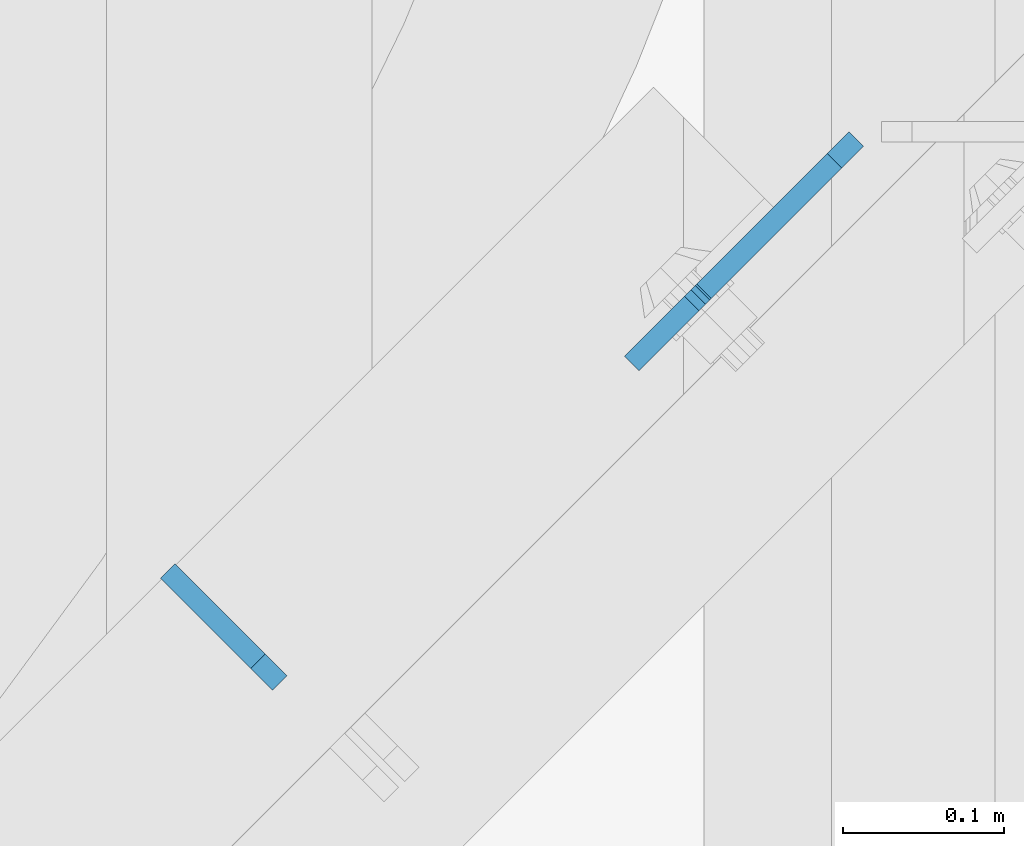
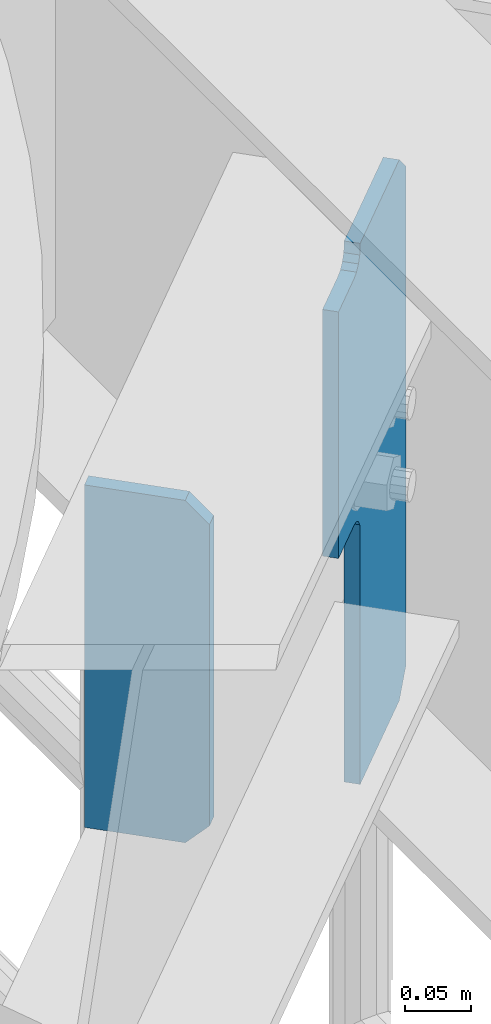
# One storey, part 1513 of 1876: 2 plates, 2 elements without a shape of their own.
"""IFC2X3 building model written with IfcOpenShell, lengths in millimetres."""

import ifcopenshell
import ifcopenshell.guid

model = None  # the IFC model being written
_history = None  # IfcOwnerHistory: only IFC2X3 demands one
_inside = {}  # id of a spatial element -> (the spatial element, [elements in it])
_under = {}  # id of a project, library or spatial element -> (it, [spatial elements below it])
_declared = {}  # id of a project -> (the project, [libraries it declares])
_typed = {}  # id of a type object -> (the type object, [elements of that type])
_made_of = {}  # id of a material, layer set ... -> (it, [elements and type objects made of it])


def new_model(schema):
    """Start an empty IFC model of exactly this schema.

    Asked for "IFC4X3", IfcOpenShell would pick the latest addendum, in which some entities
    have other attributes; the version numbers below select the first issue.
    IFC2X3 requires an IfcOwnerHistory on every rooted entity: one is made here for all.
    """
    global model, _history
    if schema == "IFC4X3":
        model = ifcopenshell.file(schema_version=(4, 3, 0, 0))
    else:
        model = ifcopenshell.file(schema=schema)
    _inside.clear()
    _under.clear()
    _declared.clear()
    _typed.clear()
    _made_of.clear()
    _history = None
    if model.schema == "IFC2X3":
        org = make("IfcOrganization", Name="unknown")
        user = make(
            "IfcPersonAndOrganization",
            ThePerson=make("IfcPerson", FamilyName="unknown"),
            TheOrganization=org,
        )
        app = make(
            "IfcApplication",
            ApplicationDeveloper=org,
            Version="unknown",
            ApplicationFullName="unknown",
            ApplicationIdentifier="unknown",
        )
        _history = make(
            "IfcOwnerHistory",
            OwningUser=user,
            OwningApplication=app,
            ChangeAction="ADDED",
            CreationDate=0,
        )
    return model


def make(cls, **values):
    """One entity of the class cls with the attributes given. An attribute that is None is left unset."""
    return model.create_entity(
        cls, **{name: value for name, value in values.items() if value is not None}
    )


def rooted(cls, **values):
    """An entity with a GlobalId (a new one), such as an element, a storey or a relation."""
    return make(cls, GlobalId=ifcopenshell.guid.new(), OwnerHistory=_history, **values)


def si_unit(unit_type, name, prefix=None):
    """IfcSIUnit, for example si_unit("LENGTHUNIT", "METRE", prefix="MILLI")."""
    return make("IfcSIUnit", UnitType=unit_type, Prefix=prefix, Name=name)


def assignment(units):
    """IfcUnitAssignment: the units of a project."""
    return None if units is None else make("IfcUnitAssignment", Units=units)


def point(xyz):
    """IfcCartesianPoint."""
    return None if xyz is None else make("IfcCartesianPoint", Coordinates=xyz)


def direction(xyz):
    """IfcDirection."""
    return None if xyz is None else make("IfcDirection", DirectionRatios=xyz)


def frame(location, z_axis=None, x_axis=None):
    """IfcAxis2Placement3D, a coordinate frame: its origin and axes. An axis left out is left unset."""
    return make(
        "IfcAxis2Placement3D",
        Location=point(location),
        Axis=direction(z_axis),
        RefDirection=direction(x_axis),
    )


def origin_with_axes():
    """The frame at (0, 0, 0) with the z axis (0, 0, 1) and the x axis (1, 0, 0) written out."""
    return frame((0.0, 0.0, 0.0), z_axis=(0.0, 0.0, 1.0), x_axis=(1.0, 0.0, 0.0))


def place(relative_to, where):
    """IfcLocalPlacement: puts the frame where relative to a parent placement (None: the world)."""
    return make(
        "IfcLocalPlacement", PlacementRelTo=relative_to, RelativePlacement=where
    )


def context(
    kind, dimensions, precision=None, world=None, true_north=None, identifier=None
):
    """IfcGeometricRepresentationContext, for example the 3D "Model" context."""
    return make(
        "IfcGeometricRepresentationContext",
        ContextIdentifier=identifier,
        ContextType=kind,
        CoordinateSpaceDimension=dimensions,
        Precision=precision,
        WorldCoordinateSystem=world,
        TrueNorth=true_north,
    )


def subcontext(parent, identifier, kind, view, scale=None):
    """IfcGeometricRepresentationSubContext, for example "Body" below "Model"."""
    return make(
        "IfcGeometricRepresentationSubContext",
        ContextIdentifier=identifier,
        ContextType=kind,
        ParentContext=parent,
        TargetScale=scale,
        TargetView=view,
    )


def project(units=None, contexts=None):
    """IfcProject with its units and contexts."""
    return rooted(
        "IfcProject",
        Name="project",
        RepresentationContexts=contexts,
        UnitsInContext=assignment(units),
    )


def spatial(cls, under=None, at=None, **own):
    """A site, building, storey or space (cls), placed at a placement, below another one or the project."""
    s = rooted(cls, ObjectPlacement=at, **own)
    if under is not None:
        _under.setdefault(under.id(), (under, []))[1].append(s)
    return s


def faces_of(points, faces, orient=None, outer=None):
    """IfcFace entities. A face is a list of loops; a loop is a list of indices into points, from 0.

    orient and outer hold one flag for each loop. By default every Orientation is true, the
    first loop of a face is its IfcFaceOuterBound and the others are IfcFaceBound.
    """
    made = []
    for i, loops in enumerate(faces):
        bounds = []
        for j, loop in enumerate(loops):
            is_outer = j == 0 if outer is None else outer[i][j]
            bounds.append(
                make(
                    "IfcFaceOuterBound" if is_outer else "IfcFaceBound",
                    Bound=make("IfcPolyLoop", Polygon=[points[k] for k in loop]),
                    Orientation=True if orient is None else orient[i][j],
                )
            )
        made.append(make("IfcFace", Bounds=bounds))
    return made


def faceted_brep(points, faces, orient=None, outer=None, voids=None):
    """IfcFacetedBrep: a solid bounded by flat faces; with voids (closed shells), ...WithVoids."""
    shared = [point(p) for p in points]
    hull = make("IfcClosedShell", CfsFaces=faces_of(shared, faces, orient, outer))
    if voids is None:
        return make("IfcFacetedBrep", Outer=hull)
    return make(
        "IfcFacetedBrepWithVoids",
        Outer=hull,
        Voids=[
            make(cls, CfsFaces=faces_of(shared, fs, o, b)) for cls, fs, o, b in voids
        ],
    )


def shape(context_of_items, identifier, shape_type, items):
    """IfcShapeRepresentation: the items that make up one representation, for example the "Body"."""
    return make(
        "IfcShapeRepresentation",
        ContextOfItems=context_of_items,
        RepresentationIdentifier=identifier,
        RepresentationType=shape_type,
        Items=items,
    )


def material(Name=None, Category=None):
    """IfcMaterial."""
    return make("IfcMaterial", Name=Name, Category=Category)


def made_of(thing, what):
    """Note that an element or type object is made of a material, layer set ...; save() writes the relation."""
    if what is not None:
        _made_of.setdefault(what.id(), (what, []))[1].append(thing)
    return thing


def type_object(cls, material=None, **own):
    """A type object (cls), such as IfcWallType, which elements share."""
    return made_of(rooted(cls, **own), material)


def element(
    cls,
    number,
    at=None,
    inside=None,
    cuts=None,
    type_object=None,
    material=None,
    context=None,
    identifier="Body",
    shape_type=None,
    held_by="IfcProductDefinitionShape",
    body=None,
    shapes=None,
    **own,
):
    """One element of the class cls, such as IfcWall. Its Tag is "e" and its number.

    at: its placement. inside: the storey or other place that contains it. cuts: it is an
    opening in that element (IfcRelVoidsElement). A single representation is given by context,
    identifier, shape_type and body (its items); several are given by shapes. held_by: the class
    of the entity that holds the representations. save() writes the other relations.
    """
    e = rooted(cls, Tag="e%d" % number, ObjectPlacement=at, **own)
    if body is not None:
        shapes = [shape(context, identifier, shape_type, body)]
    if shapes is not None:
        e.Representation = make(held_by, Representations=shapes)
    if inside is not None:
        _inside.setdefault(inside.id(), (inside, []))[1].append(e)
    if cuts is not None:
        rooted(
            "IfcRelVoidsElement", RelatingBuildingElement=cuts, RelatedOpeningElement=e
        )
    if type_object is not None:
        _typed.setdefault(type_object.id(), (type_object, []))[1].append(e)
    return made_of(e, material)


def aggregate(whole, parts):
    """IfcRelAggregates: a whole, such as a stair, and the parts it consists of."""
    return rooted("IfcRelAggregates", RelatingObject=whole, RelatedObjects=parts)


def save(model, path):
    """Write the relations noted so far, then the file.

    IfcRelAggregates (storeys below a building ...), IfcRelContainedInSpatialStructure (elements
    in a storey), IfcRelDefinesByType, IfcRelAssociatesMaterial and IfcRelDeclares: one each for
    every whole, place, type object, material and project.
    """
    for whole, parts in _under.values():
        aggregate(whole, parts)
    for where, things in _inside.values():
        rooted(
            "IfcRelContainedInSpatialStructure",
            RelatedElements=things,
            RelatingStructure=where,
        )
    for kind, things in _typed.values():
        rooted("IfcRelDefinesByType", RelatedObjects=things, RelatingType=kind)
    for what, things in _made_of.values():
        rooted("IfcRelAssociatesMaterial", RelatedObjects=things, RelatingMaterial=what)
    for by, libraries in _declared.values():
        rooted("IfcRelDeclares", RelatingContext=by, RelatedDefinitions=libraries)
    model.write(path)


model = new_model("IFC2X3")

# Units and contexts
model_context = context("Model", 3, precision=1e-05, world=origin_with_axes())
body_context = subcontext(model_context, "Body", "Model", "MODEL_VIEW")
ifc_project = project(units=[si_unit("LENGTHUNIT", "METRE", prefix="MILLI"), si_unit("AREAUNIT", "SQUARE_METRE"), si_unit("VOLUMEUNIT", "CUBIC_METRE"), si_unit("MASSUNIT", "GRAM", prefix="KILO"), si_unit("TIMEUNIT", "SECOND"), si_unit("PLANEANGLEUNIT", "RADIAN"), si_unit("SOLIDANGLEUNIT", "STERADIAN"), si_unit("THERMODYNAMICTEMPERATUREUNIT", "DEGREE_CELSIUS"), si_unit("LUMINOUSINTENSITYUNIT", "LUMEN")], contexts=[model_context])

# Site, building, storey
site_placement = place(None, origin_with_axes())
site = spatial("IfcSite", under=ifc_project, at=site_placement, CompositionType="ELEMENT")
building_placement = place(site_placement, origin_with_axes())
building = spatial("IfcBuilding", under=site, at=building_placement, Name="Undefined", CompositionType="ELEMENT")
storey_placement = place(building_placement, origin_with_axes())
storey = spatial("IfcBuildingStorey", under=building, at=storey_placement, Name="Undefined", CompositionType="ELEMENT", Elevation=0.0)

# Assembly, plate
assembly_1_placement = place(storey_placement, origin_with_axes())
assembly_1 = element("IfcElementAssembly", 1, at=assembly_1_placement, inside=storey, Name="BEAM", AssemblyPlace="NOTDEFINED", PredefinedType="RIGID_FRAME")
ifc_material = material(Name="STEEL/A36")
plate_type_1 = type_object("IfcPlateType", PredefinedType="NOTDEFINED")
plate_1_placement = place(assembly_1_placement, frame((6273.43849261577, -2803.09844321652, 7820.025), z_axis=(0.0, 0.0, 1.0), x_axis=(-0.707106781186548, 0.707106781186547, 0.0)))
plate_1 = element("IfcPlate", 2, at=plate_1_placement, type_object=plate_type_1, material=ifc_material, Name="PLATE", context=body_context, shape_type="Brep", body=[
    faceted_brep([(0.0, -6.35000000000196, 19.0499992370605), (0.0, -6.35000000000196, 298.450000762939), (0.0, 6.35000000000105, 298.450000762939), (0.0, 6.35000000000105, 19.0499992370605), (19.0499992370642, -6.35000000000105, 317.5), (19.0499992370633, 6.35000000000105, 317.5), (98.425003051776, -6.34999999999832, 317.5), (98.425003051776, 6.35000000000423, 317.5), (98.425003051776, -6.34999999999832, 0.0), (98.425003051776, 6.35000000000423, 0.0), (19.0499992370642, -6.35000000000105, 0.0), (19.0499992370633, 6.35000000000105, 0.0)], [[[0, 1, 2, 3]], [[1, 4, 5, 2]], [[4, 6, 7, 5]], [[6, 8, 9, 7]], [[8, 10, 11, 9]], [[10, 0, 3, 11]], [[5, 7, 9, 11, 3, 2]], [[10, 8, 6, 4, 1, 0]]]),
])
aggregate(assembly_1, [plate_1])

assembly_2_placement = place(storey_placement, origin_with_axes())
assembly_2 = element("IfcElementAssembly", 3, at=assembly_2_placement, inside=storey, Name="BEAM", AssemblyPlace="NOTDEFINED", PredefinedType="RIGID_FRAME")
plate_type_2 = type_object("IfcPlateType", PredefinedType="NOTDEFINED")
plate_2_placement = place(assembly_2_placement, frame((6632.05362281474, -2464.68901855855, 7653.3375), z_axis=(-0.500000092934026, -0.499999906934027, 0.707106781279836), x_axis=(-0.500000093065956, -0.499999907065956, -0.70710678109326)))
plate_2 = element("IfcPlate", 4, at=plate_2_placement, type_object=plate_type_2, material=ifc_material, Name="PLATE", context=body_context, shape_type="Brep", body=[
    faceted_brep([(0.0, -6.35000000000036, 0.0), (-327.779357909983, -6.34999999999945, 327.779357910018), (-327.779357909984, 6.34999999999945, 327.779357910018), (0.0, 6.35000000000036, 0.0), (-327.779357909974, -6.34999999999673, 354.720123290871), (-327.779357909975, 6.35000000000218, 354.72012329087), (-246.521087646294, -6.34999999997945, 435.978363036958), (-246.521087646295, 6.35000000001946, 435.978363036957), (-244.276026676376, -6.34999999997945, 433.733304414544), (-244.276026676377, 6.35000000001855, 433.733304414543), (-238.610784886918, -6.34999999997945, 429.947914446682), (-238.610784886918, 6.35000000001946, 429.947914446682), (-231.928178155422, -6.34999999997854, 428.618663148393), (-231.928178155423, 6.35000000001946, 428.618663148392), (-225.245571892809, -6.34999999997763, 429.947916803919), (-225.24557189281, 6.35000000001946, 429.947916803918), (-219.580331438615, -6.34999999997672, 433.73330877015), (-219.580331438616, 6.35000000002219, 433.73330877015), (-187.068817138485, -6.34999999997035, 466.244812011571), (-187.068817138485, 6.35000000002856, 466.244812011571), (-25.4242095946238, -6.34999999997035, 304.600189208904), (-25.4242095946247, 6.35000000002856, 304.600189208903), (-57.9357132390196, -6.34999999997672, 272.088696623216), (-57.9357132390196, 6.35000000002128, 272.088696623214), (-61.7211085739791, -6.34999999997763, 266.423453976015), (-61.72110857398, 6.35000000002128, 266.423453976014), (-63.0503630608664, -6.34999999997854, 259.740844111398), (-63.0503630608673, 6.35000000002037, 259.740844111397), (-61.7211097105192, -6.34999999997945, 253.058234020711), (-61.7211097105201, 6.35000000001946, 253.058234020711), (-57.935715339072, -6.34999999997945, 247.392990729717), (-57.9357153390729, 6.35000000001855, 247.392990729716), (108.199020385746, -6.34999999997854, 81.258255004881), (108.199020385745, 6.35000000001946, 81.258255004881), (26.9407691955512, -6.34999999999582, 4.54747350886464e-12), (26.9407691955503, 6.35000000000309, 3.63797880709171e-12)], [[[0, 1, 2, 3]], [[1, 4, 5, 2]], [[4, 6, 7, 5]], [[6, 8, 9, 7]], [[8, 10, 11, 9]], [[10, 12, 13, 11]], [[12, 14, 15, 13]], [[14, 16, 17, 15]], [[16, 18, 19, 17]], [[18, 20, 21, 19]], [[20, 22, 23, 21]], [[22, 24, 25, 23]], [[24, 26, 27, 25]], [[26, 28, 29, 27]], [[28, 30, 31, 29]], [[30, 32, 33, 31]], [[32, 34, 35, 33]], [[34, 0, 3, 35]], [[5, 7, 9, 11, 13, 15, 17, 19, 21, 23, 25, 27, 29, 31, 33, 35, 3, 2]], [[34, 32, 30, 28, 26, 24, 22, 20, 18, 16, 14, 12, 10, 8, 6, 4, 1, 0]]]),
])
aggregate(assembly_2, [plate_2])

save(model, "model.ifc")
